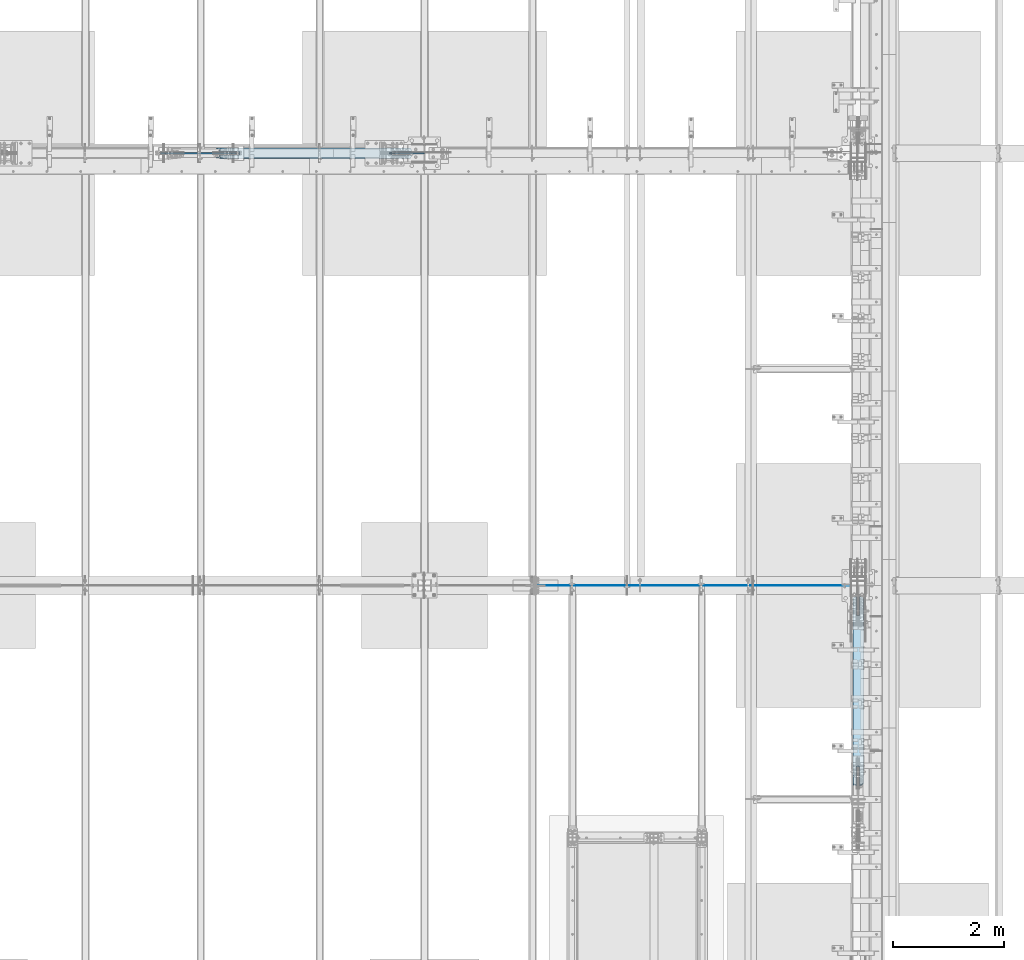
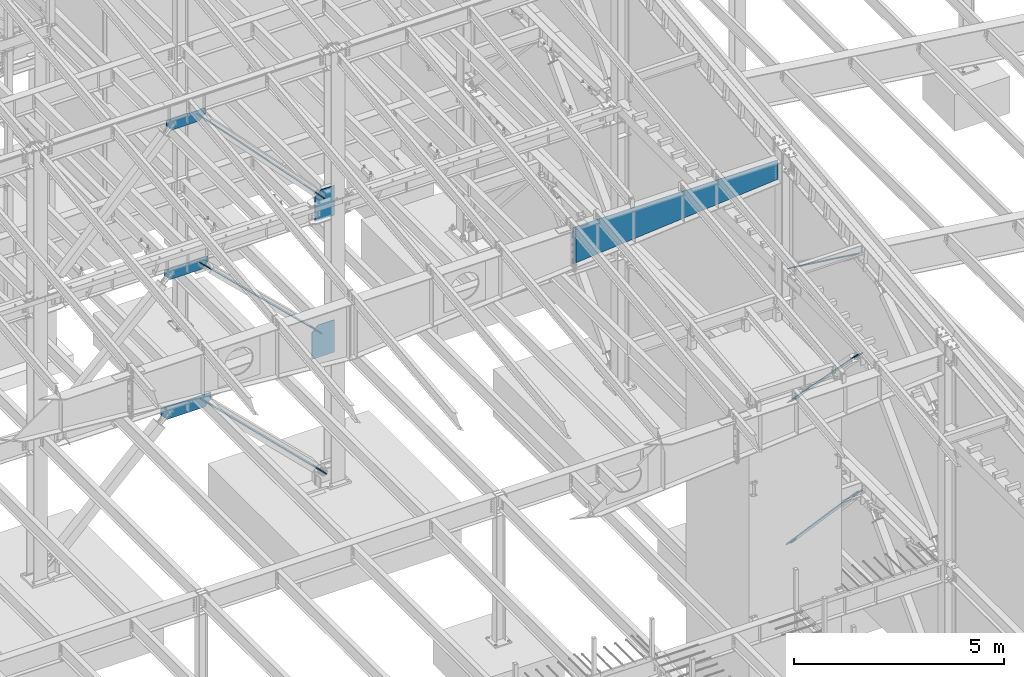
# One storey, part 975 of 1179: 12 plates, 11 elements without a shape of their own.
"""IFC2X3 building model written with IfcOpenShell, lengths in millimetres."""

from ifc_helpers import new_model, si_unit, frame, origin_with_axes, place, context, subcontext, project, spatial, faceted_brep, material, type_object, element, aggregate, save


model = new_model("IFC2X3")

# Units and contexts
model_context = context("Model", 3, precision=1e-05, world=origin_with_axes())
body_context = subcontext(model_context, "Body", "Model", "MODEL_VIEW")
ifc_project = project(units=[si_unit("LENGTHUNIT", "METRE", prefix="MILLI"), si_unit("AREAUNIT", "SQUARE_METRE"), si_unit("VOLUMEUNIT", "CUBIC_METRE"), si_unit("MASSUNIT", "GRAM", prefix="KILO"), si_unit("TIMEUNIT", "SECOND"), si_unit("PLANEANGLEUNIT", "RADIAN"), si_unit("SOLIDANGLEUNIT", "STERADIAN"), si_unit("THERMODYNAMICTEMPERATUREUNIT", "DEGREE_CELSIUS"), si_unit("LUMINOUSINTENSITYUNIT", "LUMEN")], contexts=[model_context])

# Site, building, storey
site_placement = place(None, origin_with_axes())
site = spatial("IfcSite", under=ifc_project, at=site_placement, CompositionType="ELEMENT")
building_placement = place(site_placement, origin_with_axes())
building = spatial("IfcBuilding", under=site, at=building_placement, Name="Undefined", CompositionType="ELEMENT")
storey_placement = place(building_placement, origin_with_axes())
storey = spatial("IfcBuildingStorey", under=building, at=storey_placement, Name="Undefined", CompositionType="ELEMENT", Elevation=0.0)

# Assembly, plate
assembly_1_placement = place(storey_placement, origin_with_axes())
assembly_1 = element("IfcElementAssembly", 1, at=assembly_1_placement, inside=storey, Name="CB", AssemblyPlace="NOTDEFINED", PredefinedType="RIGID_FRAME")
ifc_material_1 = material(Name="STEEL/A36")
plate_type_1 = type_object("IfcPlateType", PredefinedType="NOTDEFINED")
plate_1_placement = place(assembly_1_placement, frame((16156.2657532452, 27141.4875, 8057.37277317872), z_axis=(-0.689394506161204, 0.0, 0.724386095169385), x_axis=(0.0, -1.0, 0.0)))
plate_1 = element("IfcPlate", 2, at=plate_1_placement, type_object=plate_type_1, material=ifc_material_1, Name="CB", context=body_context, shape_type="Brep", body=[
    faceted_brep([(0.0, -6.34999999991851, 71.4374999999018), (0.0, -6.3500000028107, 4998.7655718502), (0.0, 6.34999999719003, 4998.7655718502), (0.0, 6.35000000007858, 71.4374999999018), (5.43785589622348, -6.35000000282525, 5026.1035195498), (5.43785589622348, 6.34999999717184, 5026.10351954979), (20.9235593189878, -6.35000000283981, 5049.27951253124), (20.9235593189878, 6.34999999716092, 5049.27951253124), (44.0995523004203, -6.35000000284708, 5064.76521595401), (44.0995523004203, 6.34999999715001, 5064.76521595401), (71.4375, -6.35000000285072, 5070.20307185024), (71.4375, 6.34999999715001, 5070.20307185024), (71.4375, -6.35000000261425, 4650.48058295178), (71.4375, 6.34999999738284, 4650.48058295178), (109.537499999999, -6.35000000261425, 4650.48058295178), (109.537499999999, 6.34999999738284, 4650.48058295178), (109.537499999999, -6.35000000285072, 5070.20307185024), (109.537499999999, 6.34999999715001, 5070.20307185024), (136.875447699578, -6.35000000284708, 5064.76521595401), (136.875447699578, 6.34999999715001, 5064.76521595401), (160.051440681011, -6.35000000283981, 5049.27951253124), (160.051440681011, 6.34999999716092, 5049.27951253124), (175.537144103775, -6.35000000282525, 5026.1035195498), (175.537144103775, 6.34999999717184, 5026.10351954979), (180.974999999999, -6.3500000028107, 4998.7655718502), (180.974999999999, 6.34999999719003, 4998.7655718502), (180.975000000006, -6.34999999991851, 71.4374999999018), (180.975000000006, 6.35000000007858, 71.4374999999018), (175.537144103779, -6.34999999995125, 44.0995523003585), (175.537144103779, 6.35000000004584, 44.0995523003585), (160.051440681018, -6.34999999997672, 20.9235593189551), (160.051440681018, 6.35000000002401, 20.9235593189587), (136.875447699589, -6.34999999999491, 5.43785589621984), (136.875447699589, 6.35000000000218, 5.43785589621621), (109.537500000006, -6.34999999999854, 3.63797880709171e-12), (109.537500000006, 6.35000000000218, 0.0), (109.537500000006, -6.34999999953288, 419.722488898133), (109.537500000006, 6.35000000046784, 419.722488898133), (71.4375, -6.34999999953288, 419.722488898133), (71.4375, 6.35000000046784, 419.722488898133), (71.4375, -6.34999999999854, 3.63797880709171e-12), (71.4375, 6.35000000000218, 0.0), (44.0995523004167, -6.34999999999491, 5.43785589621984), (44.0995523004167, 6.35000000000218, 5.43785589621621), (20.9235593189878, -6.34999999997672, 20.9235593189551), (20.9235593189878, 6.35000000002401, 20.9235593189587), (5.43785589622712, -6.34999999995125, 44.0995523003585), (5.43785589622712, 6.35000000004584, 44.0995523003585)], [[[0, 1, 2, 3]], [[1, 4, 5, 2]], [[4, 6, 7, 5]], [[6, 8, 9, 7]], [[8, 10, 11, 9]], [[10, 12, 13, 11]], [[12, 14, 15, 13]], [[14, 16, 17, 15]], [[16, 18, 19, 17]], [[18, 20, 21, 19]], [[20, 22, 23, 21]], [[22, 24, 25, 23]], [[24, 26, 27, 25]], [[26, 28, 29, 27]], [[28, 30, 31, 29]], [[30, 32, 33, 31]], [[32, 34, 35, 33]], [[34, 36, 37, 35]], [[36, 38, 39, 37]], [[38, 40, 41, 39]], [[40, 42, 43, 41]], [[42, 44, 45, 43]], [[44, 46, 47, 45]], [[46, 0, 3, 47]], [[5, 7, 9, 11, 13, 15, 17, 19, 21, 23, 25, 27, 29, 31, 33, 35, 37, 39, 41, 43, 45, 47, 3, 2]], [[46, 44, 42, 40, 38, 36, 34, 32, 30, 28, 26, 24, 22, 20, 18, 16, 14, 12, 10, 8, 6, 4, 1, 0]]]),
])
aggregate(assembly_1, [plate_1])

assembly_2_placement = place(storey_placement, origin_with_axes())
assembly_2 = element("IfcElementAssembly", 3, at=assembly_2_placement, inside=storey, Name="CB", AssemblyPlace="NOTDEFINED", PredefinedType="RIGID_FRAME")
plate_2_placement = place(assembly_2_placement, frame((24217.3125, 18933.9955492494, 8077.03369074013), z_axis=(0.0, -0.806042322895358, 0.591857899923162), x_axis=(1.0, 0.0, 0.0)))
plate_2 = element("IfcPlate", 4, at=plate_2_placement, type_object=plate_type_1, material=ifc_material_1, Name="CB", context=body_context, shape_type="Brep", body=[
    faceted_brep([(0.0, -6.34999999991851, 71.4374999999018), (0.0, -6.35000000333093, 3879.50747780775), (0.0, 6.34999999666252, 3879.50747780777), (0.0, 6.35000000007858, 71.4374999999018), (5.43785589622496, -6.3500000033564, 3906.84542550735), (5.43785589622496, 6.34999999664069, 3906.84542550736), (20.923559318986, -6.35000000337459, 3930.0214184888), (20.923559318986, 6.34999999661886, 3930.02141848881), (44.0995523004189, -6.3500000033855, 3945.50712191157), (44.0995523004189, 6.34999999660431, 3945.50712191158), (71.4375, -6.35000000339278, 3950.9449778078), (71.4375, 6.34999999660431, 3950.94497780781), (71.4375, -6.35000000303262, 3531.22248890774), (71.4375, 6.34999999696083, 3531.22248890776), (109.537499999999, -6.35000000303262, 3531.22248890774), (109.537499999999, 6.34999999696083, 3531.22248890776), (109.537499999999, -6.35000000339278, 3950.9449778078), (109.537499999999, 6.34999999660431, 3950.94497780781), (136.87544769958, -6.3500000033855, 3945.50712191157), (136.87544769958, 6.34999999660431, 3945.50712191158), (160.051440681012, -6.35000000337459, 3930.0214184888), (160.051440681012, 6.34999999661886, 3930.02141848881), (175.537144103774, -6.3500000033564, 3906.84542550735), (175.537144103774, 6.34999999664069, 3906.84542550736), (180.974999999999, -6.35000000333093, 3879.50747780775), (180.974999999999, 6.34999999666252, 3879.50747780777), (180.975000000006, -6.34999999991851, 71.4374999999018), (180.975000000006, 6.35000000007858, 71.4374999999018), (175.537144103779, -6.34999999995125, 44.0995523003585), (175.537144103779, 6.35000000004584, 44.0995523003585), (160.051440681018, -6.34999999997672, 20.9235593189551), (160.051440681018, 6.35000000002401, 20.9235593189587), (136.875447699589, -6.34999999999491, 5.43785589621984), (136.875447699589, 6.35000000000218, 5.43785589621621), (109.537500000006, -6.34999999999854, 3.63797880709171e-12), (109.537500000006, 6.35000000000218, 0.0), (109.537500000006, -6.34999999953288, 419.722488898133), (109.537500000006, 6.35000000046784, 419.722488898133), (71.4375, -6.34999999953288, 419.722488898133), (71.4375, 6.35000000046784, 419.722488898133), (71.4375, -6.34999999999854, 3.63797880709171e-12), (71.4375, 6.35000000000218, 0.0), (44.0995523004167, -6.34999999999491, 5.43785589621984), (44.0995523004167, 6.35000000000218, 5.43785589621621), (20.9235593189878, -6.34999999997672, 20.9235593189551), (20.9235593189878, 6.35000000002401, 20.9235593189587), (5.43785589622712, -6.34999999995125, 44.0995523003585), (5.43785589622712, 6.35000000004584, 44.0995523003585)], [[[0, 1, 2, 3]], [[1, 4, 5, 2]], [[4, 6, 7, 5]], [[6, 8, 9, 7]], [[8, 10, 11, 9]], [[10, 12, 13, 11]], [[12, 14, 15, 13]], [[14, 16, 17, 15]], [[16, 18, 19, 17]], [[18, 20, 21, 19]], [[20, 22, 23, 21]], [[22, 24, 25, 23]], [[24, 26, 27, 25]], [[26, 28, 29, 27]], [[28, 30, 31, 29]], [[30, 32, 33, 31]], [[32, 34, 35, 33]], [[34, 36, 37, 35]], [[36, 38, 39, 37]], [[38, 40, 41, 39]], [[40, 42, 43, 41]], [[42, 44, 45, 43]], [[44, 46, 47, 45]], [[46, 0, 3, 47]], [[5, 7, 9, 11, 13, 15, 17, 19, 21, 23, 25, 27, 29, 31, 33, 35, 37, 39, 41, 43, 45, 47, 3, 2]], [[46, 44, 42, 40, 38, 36, 34, 32, 30, 28, 26, 24, 22, 20, 18, 16, 14, 12, 10, 8, 6, 4, 1, 0]]]),
])
aggregate(assembly_2, [plate_2])

assembly_3_placement = place(storey_placement, origin_with_axes())
assembly_3 = element("IfcElementAssembly", 5, at=assembly_3_placement, inside=storey, Name="CB", AssemblyPlace="NOTDEFINED", PredefinedType="RIGID_FRAME")
plate_type_2 = type_object("IfcPlateType", PredefinedType="NOTDEFINED")
plate_3_placement = place(assembly_3_placement, frame((16087.607596845, 27144.6625, 4150.42562094517), z_axis=(-0.719495300867138, 0.0, 0.694497308871752), x_axis=(0.0, -1.0, 0.0)))
plate_3 = element("IfcPlate", 6, at=plate_3_placement, type_object=plate_type_2, material=ifc_material_1, Name="CB", context=body_context, shape_type="Brep", body=[
    faceted_brep([(0.0, -9.52500000000691, 71.4375), (0.0, -9.52500000003238, 4613.90331080685), (0.0, 9.52499999997781, 4613.90331080686), (0.0, 9.52500000000327, 71.4374999999909), (5.43785589622348, -9.52500000003238, 4641.24125850645), (5.43785589622348, 9.52499999997781, 4641.24125850645), (20.9235593189878, -9.52500000003238, 4664.41725148789), (20.9235593189878, 9.52499999997781, 4664.41725148789), (44.0995523004203, -9.52500000003238, 4679.90295491066), (44.0995523004203, 9.52499999997781, 4679.90295491066), (71.4375, -9.52500000003056, 4685.34081080689), (71.4375, 9.52499999997781, 4685.34081080689), (71.4375, -9.52500000002874, 4263.75907000934), (71.4375, 9.52499999998145, 4263.75907000934), (115.887499999997, -9.52500000002874, 4263.75907000934), (115.887499999997, 9.52499999998145, 4263.75907000934), (115.887499999997, -9.52500000003056, 4685.34081080689), (115.887499999997, 9.52499999997781, 4685.34081080689), (143.225447699577, -9.52500000003238, 4679.90295491066), (143.225447699577, 9.52499999997781, 4679.90295491066), (166.401440681009, -9.52500000003238, 4664.41725148789), (166.401440681009, 9.52499999997781, 4664.41725148789), (181.887144103774, -9.52500000003238, 4641.24125850645), (181.887144103774, 9.52499999997781, 4641.24125850645), (187.324999999997, -9.52500000003238, 4613.90331080685), (187.324999999997, 9.52499999997781, 4613.90331080686), (187.324999999997, -9.52500000000691, 71.4375), (187.324999999997, 9.52500000000327, 71.4374999999909), (181.88714410377, -9.52500000000691, 44.0995523004203), (181.88714410377, 9.52500000000509, 44.0995523004112), (166.401440681009, -9.52500000000691, 20.9235593189915), (166.401440681009, 9.52500000000509, 20.9235593189787), (143.22544769958, -9.52500000000327, 5.43785589623076), (143.22544769958, 9.52500000000509, 5.43785589621621), (115.887499999997, -9.52500000000509, 5.45696821063757e-12), (115.887499999997, 9.52500000000691, -7.27595761418343e-12), (115.887499999997, -9.52500000001783, 421.581740798863), (115.887499999997, 9.52499999999418, 421.581740798851), (71.4375, -9.52500000001783, 421.581740798863), (71.4375, 9.52499999999418, 421.581740798851), (71.4375, -9.52500000000509, 5.45696821063757e-12), (71.4375, 9.52500000000691, -7.27595761418343e-12), (44.0995523004167, -9.52500000000327, 5.43785589623076), (44.0995523004167, 9.52500000000509, 5.43785589621621), (20.9235593189878, -9.52500000000691, 20.9235593189915), (20.9235593189878, 9.52500000000509, 20.9235593189787), (5.43785589622712, -9.52500000000691, 44.0995523004203), (5.43785589622712, 9.52500000000509, 44.0995523004112)], [[[0, 1, 2, 3]], [[1, 4, 5, 2]], [[4, 6, 7, 5]], [[6, 8, 9, 7]], [[8, 10, 11, 9]], [[10, 12, 13, 11]], [[12, 14, 15, 13]], [[14, 16, 17, 15]], [[16, 18, 19, 17]], [[18, 20, 21, 19]], [[20, 22, 23, 21]], [[22, 24, 25, 23]], [[24, 26, 27, 25]], [[26, 28, 29, 27]], [[28, 30, 31, 29]], [[30, 32, 33, 31]], [[32, 34, 35, 33]], [[34, 36, 37, 35]], [[36, 38, 39, 37]], [[38, 40, 41, 39]], [[40, 42, 43, 41]], [[42, 44, 45, 43]], [[44, 46, 47, 45]], [[46, 0, 3, 47]], [[5, 7, 9, 11, 13, 15, 17, 19, 21, 23, 25, 27, 29, 31, 33, 35, 37, 39, 41, 43, 45, 47, 3, 2]], [[46, 44, 42, 40, 38, 36, 34, 32, 30, 28, 26, 24, 22, 20, 18, 16, 14, 12, 10, 8, 6, 4, 1, 0]]]),
])
aggregate(assembly_3, [plate_3])

assembly_4_placement = place(storey_placement, origin_with_axes())
assembly_4 = element("IfcElementAssembly", 7, at=assembly_4_placement, inside=storey, Name="CB", AssemblyPlace="NOTDEFINED", PredefinedType="RIGID_FRAME")
plate_4_placement = place(assembly_4_placement, frame((24214.1375, 18978.4459530966, 4148.03570454913), z_axis=(0.0, -0.69846692303685, 0.715642339037759), x_axis=(1.0, 0.0, 0.0)))
plate_4 = element("IfcPlate", 8, at=plate_4_placement, type_object=plate_type_2, material=ifc_material_1, Name="CB", context=body_context, shape_type="Brep", body=[
    faceted_brep([(0.0, -9.52500000000691, 71.4375), (0.0, -9.52499999965221, 4791.84892355422), (0.0, 9.52500000033979, 4791.84892355423), (0.0, 9.52500000000327, 71.4374999999909), (5.43785589622496, -9.52499999964857, 4819.1868712538), (5.43785589622496, 9.52500000034343, 4819.18687125381), (20.923559318986, -9.52499999964857, 4842.36286423524), (20.923559318986, 9.52500000034343, 4842.36286423525), (44.0995523004189, -9.52499999964493, 4857.848567658), (44.0995523004189, 9.52500000034343, 4857.84856765801), (71.4375, -9.52499999964493, 4863.28642355423), (71.4375, 9.52500000034706, 4863.28642355424), (71.4375, -9.52499999967404, 4441.70468275449), (71.4375, 9.52500000031432, 4441.7046827545), (115.8875, -9.52499999967404, 4441.70468275449), (115.8875, 9.52500000031432, 4441.7046827545), (115.8875, -9.52499999964493, 4863.28642355423), (115.8875, 9.52500000034706, 4863.28642355424), (143.225447699581, -9.52499999964493, 4857.848567658), (143.225447699581, 9.52500000034343, 4857.84856765801), (166.401440681014, -9.52499999964857, 4842.36286423524), (166.401440681014, 9.52500000034343, 4842.36286423525), (181.887144103775, -9.52499999964857, 4819.1868712538), (181.887144103775, 9.52500000034343, 4819.18687125381), (187.325, -9.52499999965221, 4791.84892355422), (187.325, 9.52500000033979, 4791.84892355423), (187.324999999997, -9.52500000000691, 71.4375), (187.324999999997, 9.52500000000327, 71.4374999999909), (181.88714410377, -9.52500000000691, 44.0995523004203), (181.88714410377, 9.52500000000509, 44.0995523004112), (166.401440681009, -9.52500000000691, 20.9235593189915), (166.401440681009, 9.52500000000509, 20.9235593189787), (143.22544769958, -9.52500000000327, 5.43785589623076), (143.22544769958, 9.52500000000509, 5.43785589621621), (115.887499999997, -9.52500000000509, 5.45696821063757e-12), (115.887499999997, 9.52500000000691, -7.27595761418343e-12), (115.887499999997, -9.52500000001783, 421.581740798863), (115.887499999997, 9.52499999999418, 421.581740798851), (71.4375, -9.52500000001783, 421.581740798863), (71.4375, 9.52499999999418, 421.581740798851), (71.4375, -9.52500000000509, 5.45696821063757e-12), (71.4375, 9.52500000000691, -7.27595761418343e-12), (44.0995523004167, -9.52500000000327, 5.43785589623076), (44.0995523004167, 9.52500000000509, 5.43785589621621), (20.9235593189878, -9.52500000000691, 20.9235593189915), (20.9235593189878, 9.52500000000509, 20.9235593189787), (5.43785589622712, -9.52500000000691, 44.0995523004203), (5.43785589622712, 9.52500000000509, 44.0995523004112)], [[[0, 1, 2, 3]], [[1, 4, 5, 2]], [[4, 6, 7, 5]], [[6, 8, 9, 7]], [[8, 10, 11, 9]], [[10, 12, 13, 11]], [[12, 14, 15, 13]], [[14, 16, 17, 15]], [[16, 18, 19, 17]], [[18, 20, 21, 19]], [[20, 22, 23, 21]], [[22, 24, 25, 23]], [[24, 26, 27, 25]], [[26, 28, 29, 27]], [[28, 30, 31, 29]], [[30, 32, 33, 31]], [[32, 34, 35, 33]], [[34, 36, 37, 35]], [[36, 38, 39, 37]], [[38, 40, 41, 39]], [[40, 42, 43, 41]], [[42, 44, 45, 43]], [[44, 46, 47, 45]], [[46, 0, 3, 47]], [[5, 7, 9, 11, 13, 15, 17, 19, 21, 23, 25, 27, 29, 31, 33, 35, 37, 39, 41, 43, 45, 47, 3, 2]], [[46, 44, 42, 40, 38, 36, 34, 32, 30, 28, 26, 24, 22, 20, 18, 16, 14, 12, 10, 8, 6, 4, 1, 0]]]),
])
aggregate(assembly_4, [plate_4])

assembly_5_placement = place(storey_placement, origin_with_axes())
assembly_5 = element("IfcElementAssembly", 9, at=assembly_5_placement, inside=storey, Name="CB", AssemblyPlace="NOTDEFINED", PredefinedType="RIGID_FRAME")
plate_type_3 = type_object("IfcPlateType", PredefinedType="NOTDEFINED")
plate_5_placement = place(assembly_5_placement, frame((16219.9942171892, 27147.8375, 18.4770949867459), z_axis=(-0.714279370137245, 0.0, 0.699860687134476), x_axis=(0.0, -1.0, 0.0)))
plate_5 = element("IfcPlate", 10, at=plate_5_placement, type_object=plate_type_3, material=ifc_material_1, Name="CB", context=body_context, shape_type="Brep", body=[
    faceted_brep([(0.0, -12.6999999999871, 65.0875015258525), (0.0, -12.6999999987202, 4798.7012416261), (0.0, 12.7000000012849, 4798.70124162609), (0.0, 12.7000000000194, 65.0875015258407), (4.95449104382351, -12.6999999987129, 4823.60915011408), (4.95449104382351, 12.7000000012922, 4823.60915011408), (19.0636878264413, -12.6999999987092, 4844.72505532553), (19.0636878264413, 12.7000000012977, 4844.72505532552), (40.1795930378867, -12.6999999987038, 4858.83425210814), (40.1795930378867, 12.7000000012995, 4858.83425210813), (65.0875000000015, -12.699999998702, 4863.78874315196), (65.0875000000015, 12.7000000013031, 4863.78874315195), (65.0875000000015, -12.6999999988366, 4364.12194395591), (65.0875000000015, 12.7000000011685, 4364.1219439559), (128.587500000001, -12.6999999988366, 4364.12194395591), (128.587500000001, 12.7000000011685, 4364.1219439559), (128.587498474124, -12.699999998702, 4863.78874315196), (128.587498474124, 12.7000000013031, 4863.78874315195), (153.495406962116, -12.6999999987038, 4858.83425210814), (153.495406962116, 12.7000000012995, 4858.83425210813), (174.611312173562, -12.6999999987092, 4844.72505532553), (174.611312173562, 12.7000000012977, 4844.72505532552), (188.720508956179, -12.6999999987129, 4823.60915011408), (188.720508956179, 12.7000000012922, 4823.60915011408), (193.675000000003, -12.6999999987202, 4798.7012416261), (193.675000000003, 12.7000000012849, 4798.70124162609), (193.675000000003, -12.6999999999871, 65.0875015258525), (193.675000000003, 12.7000000000194, 65.0875015258407), (188.720508956183, -12.6999999999939, 40.1795930378748), (188.720508956183, 12.7000000000126, 40.179593037863), (174.611312173562, -12.6999999999985, 19.0636878264377), (174.611312173562, 12.7000000000075, 19.0636878264249), (153.495406962116, -12.7000000000016, 4.95449104382624), (153.495406962116, 12.7000000000044, 4.95449104381441), (128.587500000001, -12.7000000000035, 8.18545231595635e-12), (128.587500000001, 12.700000000003, -6.3664629124105e-12), (128.587500000001, -12.6999999998793, 499.666799194779), (128.587500000001, 12.7000000001267, 499.666799194767), (65.0875000000015, -12.6999999998793, 499.666799194779), (65.0875000000015, 12.7000000001267, 499.666799194767), (65.0875015258789, -12.7000000000035, 8.18545231595635e-12), (65.0875015258789, 12.700000000003, -6.3664629124105e-12), (40.1795930378867, -12.7000000000016, 4.95449104382624), (40.1795930378867, 12.7000000000044, 4.95449104381441), (19.0636878264413, -12.6999999999985, 19.0636878264377), (19.0636878264413, 12.7000000000075, 19.0636878264249), (4.95449104381987, -12.6999999999939, 40.1795930378748), (4.95449104381987, 12.7000000000126, 40.179593037863)], [[[0, 1, 2, 3]], [[1, 4, 5, 2]], [[4, 6, 7, 5]], [[6, 8, 9, 7]], [[8, 10, 11, 9]], [[10, 12, 13, 11]], [[12, 14, 15, 13]], [[14, 16, 17, 15]], [[16, 18, 19, 17]], [[18, 20, 21, 19]], [[20, 22, 23, 21]], [[22, 24, 25, 23]], [[24, 26, 27, 25]], [[26, 28, 29, 27]], [[28, 30, 31, 29]], [[30, 32, 33, 31]], [[32, 34, 35, 33]], [[34, 36, 37, 35]], [[36, 38, 39, 37]], [[38, 40, 41, 39]], [[40, 42, 43, 41]], [[42, 44, 45, 43]], [[44, 46, 47, 45]], [[46, 0, 3, 47]], [[5, 7, 9, 11, 13, 15, 17, 19, 21, 23, 25, 27, 29, 31, 33, 35, 37, 39, 41, 43, 45, 47, 3, 2]], [[46, 44, 42, 40, 38, 36, 34, 32, 30, 28, 26, 24, 22, 20, 18, 16, 14, 12, 10, 8, 6, 4, 1, 0]]]),
])
aggregate(assembly_5, [plate_5])

# Assembly, plates
assembly_6_placement = place(storey_placement, origin_with_axes())
assembly_6 = element("IfcElementAssembly", 11, at=assembly_6_placement, inside=storey, Name="COLUMN", AssemblyPlace="NOTDEFINED", PredefinedType="RIGID_FRAME")
ifc_material_2 = material(Name="STEEL/A572-GR.50")
plate_type_4 = type_object("IfcPlateType", PredefinedType="NOTDEFINED")
plate_6_placement = place(assembly_6_placement, frame((16452.8499999999, 27051.0, 7445.375), z_axis=(0.0, 0.0, 1.0), x_axis=(-1.0, 0.0, 0.0)))
plate_6 = element("IfcPlate", 12, at=plate_6_placement, type_object=plate_type_4, material=ifc_material_2, Name="PLATE", context=body_context, shape_type="Brep", body=[
    faceted_brep([(0.0, -9.52499999999964, 0.0), (-1.41881173476577e-10, -9.52500000000146, 862.535414371277), (-1.41881173476577e-10, 9.52500000000146, 862.535414371277), (0.0, 9.52499999999964, 0.0), (375.039332806891, -9.52500000000146, 862.535414371277), (375.039332806891, 9.52500000000146, 862.535414371277), (542.933920014775, -9.52500000000146, 702.751002705763), (542.933920014775, 9.52500000000146, 702.751002705763), (542.933920014915, -9.52500000000146, 0.0), (542.933920014915, 9.52500000000146, 0.0)], [[[0, 1, 2, 3]], [[1, 4, 5, 2]], [[4, 6, 7, 5]], [[6, 8, 9, 7]], [[8, 0, 3, 9]], [[5, 7, 9, 3, 2]], [[8, 6, 4, 1, 0]]]),
])
plate_type_5 = type_object("IfcPlateType", PredefinedType="NOTDEFINED")
plate_7_placement = place(assembly_6_placement, frame((16452.85, 27051.0, 3460.75), z_axis=(0.0, 0.0, 1.0), x_axis=(-1.0, 0.0, 0.0)))
plate_7 = element("IfcPlate", 13, at=plate_7_placement, type_object=plate_type_5, material=ifc_material_2, Name="PLATE", context=body_context, shape_type="Brep", body=[
    faceted_brep([(0.0, -9.52499999999964, 0.0), (0.0, -9.52500000000146, 940.236235231712), (0.0, 9.52500000000146, 940.236235231712), (0.0, 9.52499999999964, 0.0), (453.384839102724, -9.52500000000146, 940.236235231712), (453.384839102724, 9.52500000000146, 940.236235231712), (618.762010777811, -9.52500000000146, 768.906416712725), (618.762010777811, 9.52500000000146, 768.906416712725), (618.762010777811, -9.52500000000146, 0.0), (618.762010777811, 9.52500000000146, 0.0)], [[[0, 1, 2, 3]], [[1, 4, 5, 2]], [[4, 6, 7, 5]], [[6, 8, 9, 7]], [[8, 0, 3, 9]], [[5, 7, 9, 3, 2]], [[8, 6, 4, 1, 0]]]),
])
aggregate(assembly_6, [plate_6, plate_7])

# Assembly, plate
assembly_7_placement = place(storey_placement, origin_with_axes())
assembly_7 = element("IfcElementAssembly", 14, at=assembly_7_placement, inside=storey, Name="BEAM", AssemblyPlace="NOTDEFINED", PredefinedType="RIGID_FRAME")
plate_type_6 = type_object("IfcPlateType", PredefinedType="NOTDEFINED")
plate_8_placement = place(assembly_7_placement, frame((11682.7933815895, 27051.0, 3288.94554728214), z_axis=(1.0, 0.0, 0.0), x_axis=(0.0, 0.0, 1.0)))
plate_8 = element("IfcPlate", 15, at=plate_8_placement, type_object=plate_type_6, material=ifc_material_2, Name="PLATE", context=body_context, shape_type="Brep", body=[
    faceted_brep([(0.0, -12.7, 0.0), (-174.623449014303, -12.7000000000007, 171.0984414872), (-174.623449014303, 12.7000000000007, 171.0984414872), (0.0, 12.7, 0.0), (-174.623449014303, -12.7000000000007, 693.356618597156), (-174.623449014303, 12.7000000000007, 693.356618597156), (-174.623449014303, -12.7000000000007, 1202.91479533381), (-174.623449014303, 12.7000000000007, 1202.91479533381), (1.86613760888577e-07, -12.7000000000007, 1374.01323700385), (1.86613760888577e-07, 12.7000000000007, 1374.01323700385), (190.85445271786, -12.7000000000007, 1374.01323700385), (190.85445271786, 12.7000000000007, 1374.01323700385), (190.85445271786, -12.7000000000007, 0.0), (190.85445271786, 12.7000000000007, 0.0)], [[[0, 1, 2, 3]], [[1, 4, 5, 2]], [[4, 6, 7, 5]], [[6, 8, 9, 7]], [[8, 10, 11, 9]], [[10, 12, 13, 11]], [[12, 0, 3, 13]], [[5, 7, 9, 11, 13, 3, 2]], [[12, 10, 8, 6, 4, 1, 0]]]),
])
aggregate(assembly_7, [plate_8])

assembly_8_placement = place(storey_placement, origin_with_axes())
assembly_8 = element("IfcElementAssembly", 16, at=assembly_8_placement, inside=storey, Name="BEAM", AssemblyPlace="NOTDEFINED", PredefinedType="RIGID_FRAME")
plate_type_7 = type_object("IfcPlateType", PredefinedType="NOTDEFINED")
plate_9_placement = place(assembly_8_placement, frame((11769.5534918783, 27051.0, 7325.15094989935), z_axis=(1.0, 0.0, 0.0), x_axis=(0.0, 0.0, 1.0)))
plate_9 = element("IfcPlate", 17, at=plate_9_placement, type_object=plate_type_7, material=ifc_material_2, Name="PLATE", context=body_context, shape_type="Brep", body=[
    faceted_brep([(0.0, -9.52499999999964, 0.0), (-174.871873520778, -9.52500000000146, 168.796162108289), (-174.871873520778, 9.52500000000146, 168.796162108289), (0.0, 9.52499999999964, 0.0), (-174.871873730764, -9.52500000000146, 606.596509721659), (-174.871873730764, 9.52500000000146, 606.596509721659), (-174.871873934634, -9.52500000000146, 1031.69641039643), (-174.871873934634, 9.52500000000146, 1031.69641039643), (0.000458959779280121, -9.52500000000146, 1200.49301624073), (0.000458959779280121, 9.52500000000146, 1200.49301624073), (139.274049524961, -9.52500000000146, 1200.4930163071), (139.274049524961, 9.52500000000146, 1200.4930163071), (139.274050100698, -9.52500000000146, 0.0), (139.274050100698, 9.52500000000146, 0.0)], [[[0, 1, 2, 3]], [[1, 4, 5, 2]], [[4, 6, 7, 5]], [[6, 8, 9, 7]], [[8, 10, 11, 9]], [[10, 12, 13, 11]], [[12, 0, 3, 13]], [[5, 7, 9, 11, 13, 3, 2]], [[12, 10, 8, 6, 4, 1, 0]]]),
])
aggregate(assembly_8, [plate_9])

assembly_9_placement = place(storey_placement, origin_with_axes())
assembly_9 = element("IfcElementAssembly", 18, at=assembly_9_placement, inside=storey, Name="BEAM", AssemblyPlace="NOTDEFINED", PredefinedType="RIGID_FRAME")
plate_type_8 = type_object("IfcPlateType", PredefinedType="NOTDEFINED")
plate_10_placement = place(assembly_9_placement, frame((11832.3547145402, 27051.0, 11639.4041503228), z_axis=(1.0, 0.0, 0.0), x_axis=(0.0, 0.0, 1.0)))
plate_10 = element("IfcPlate", 19, at=plate_10_placement, type_object=plate_type_8, material=ifc_material_2, Name="PLATE", context=body_context, shape_type="Brep", body=[
    faceted_brep([(0.0, -9.52499999999964, 0.0), (-159.78441340453, -9.52500000000146, 167.89458903517), (-159.78441340453, 9.52500000000146, 167.89458903517), (0.0, 9.52499999999964, 0.0), (-159.78441340453, -9.52500000000146, 543.795283632486), (-159.78441340453, 9.52500000000146, 543.795283632486), (-159.78441340453, -9.52500000000146, 906.995981884371), (-159.78441340453, 9.52500000000146, 906.995981884371), (-1.73901753441896e-06, -9.52500000000146, 1074.89056909225), (-1.73901753441896e-06, 9.52500000000146, 1074.89056909225), (163.26147471287, -9.52500000000146, 1074.89056909225), (163.26147471287, 9.52500000000146, 1074.89056909225), (163.26147471287, -9.52500000000146, 0.0), (163.26147471287, 9.52500000000146, 0.0)], [[[0, 1, 2, 3]], [[1, 4, 5, 2]], [[4, 6, 7, 5]], [[6, 8, 9, 7]], [[8, 10, 11, 9]], [[10, 12, 13, 11]], [[12, 0, 3, 13]], [[5, 7, 9, 11, 13, 3, 2]], [[12, 10, 8, 6, 4, 1, 0]]]),
])
aggregate(assembly_9, [plate_10])

assembly_10_placement = place(storey_placement, origin_with_axes())
assembly_10 = element("IfcElementAssembly", 20, at=assembly_10_placement, inside=storey, Name="CB", AssemblyPlace="NOTDEFINED", PredefinedType="RIGID_FRAME")
plate_type_9 = type_object("IfcPlateType", PredefinedType="NOTDEFINED")
plate_11_placement = place(assembly_10_placement, frame((24212.55, 19018.1469828896, 6.46967490713081), z_axis=(0.0, -0.68599585875867, 0.727605443744036), x_axis=(1.0, 0.0, 0.0)))
plate_11 = element("IfcPlate", 21, at=plate_11_placement, type_object=plate_type_9, material=ifc_material_1, Name="CB", context=body_context, shape_type="Brep", body=[
    faceted_brep([(0.0, -12.700000000139, 66.6750030518815), (0.0, -12.7000000021235, 4899.51727466588), (0.0, 12.6999999978489, 4899.5172746659), (0.0, 12.6999999998006, 66.6750030519361), (5.0753324021112, -12.7000000021344, 4925.03269368669), (5.0753324021112, 12.6999999978379, 4925.03269368671), (19.5286562582261, -12.7000000021453, 4946.66362145943), (19.5286562582261, 12.699999997827, 4946.66362145945), (41.1595840309583, -12.7000000021508, 4961.11694531555), (41.1595840309583, 12.6999999978198, 4961.11694531558), (66.675, -12.7000000021526, 4966.19227771766), (66.675, 12.6999999978179, 4966.19227771769), (66.675, -12.7000000019343, 4467.47113886627), (66.675, 12.6999999980362, 4467.4711388663), (123.825, -12.7000000019343, 4467.47113886627), (123.825, 12.6999999980362, 4467.4711388663), (123.824996948242, -12.7000000021526, 4966.19227771766), (123.824996948242, 12.6999999978179, 4966.19227771769), (149.340415969042, -12.7000000021508, 4961.11694531555), (149.340415969042, 12.6999999978198, 4961.11694531558), (170.971343741774, -12.7000000021453, 4946.66362145943), (170.971343741774, 12.699999997827, 4946.66362145945), (185.424667597889, -12.7000000021344, 4925.03269368669), (185.424667597889, 12.6999999978379, 4925.03269368671), (190.5, -12.7000000021235, 4899.51727466588), (190.5, 12.6999999978489, 4899.5172746659), (190.5, -12.700000000139, 66.6750030518815), (190.5, 12.6999999998006, 66.6750030519361), (185.424667597889, -12.7000000000735, 41.159584031022), (185.424667597889, 12.6999999998661, 41.1595840310729), (170.971343741774, -12.7000000000189, 19.5286562582405), (170.971343741774, 12.6999999999171, 19.5286562582951), (149.340415969042, -12.6999999999825, 5.07533240209159), (149.340415969042, 12.6999999999571, 5.07533240214616), (123.824999618709, -12.7000000000002, 0.0), (123.8249996187, 12.6999999999996, 0.0), (123.825, -12.7000000002045, 498.721138851377), (123.825, 12.6999999997697, 498.721138851402), (66.675, -12.7000000002045, 498.721138851377), (66.675, 12.6999999997697, 498.721138851402), (66.6750030517578, -12.699999999968, -2.91038304567337e-11), (66.6750030517578, 12.699999999968, 2.91038304567337e-11), (41.1595840309583, -12.6999999999825, 5.07533240209159), (41.1595840309583, 12.6999999999571, 5.07533240214616), (19.5286562582261, -12.7000000000189, 19.5286562582405), (19.5286562582261, 12.6999999999171, 19.5286562582951), (5.0753324021112, -12.7000000000735, 41.159584031022), (5.0753324021112, 12.6999999998661, 41.1595840310729)], [[[0, 1, 2, 3]], [[1, 4, 5, 2]], [[4, 6, 7, 5]], [[6, 8, 9, 7]], [[8, 10, 11, 9]], [[10, 12, 13, 11]], [[12, 14, 15, 13]], [[14, 16, 17, 15]], [[16, 18, 19, 17]], [[18, 20, 21, 19]], [[20, 22, 23, 21]], [[22, 24, 25, 23]], [[24, 26, 27, 25]], [[26, 28, 29, 27]], [[28, 30, 31, 29]], [[30, 32, 33, 31]], [[32, 34, 35, 33]], [[34, 36, 37, 35]], [[36, 38, 39, 37]], [[38, 40, 41, 39]], [[40, 42, 43, 41]], [[42, 44, 45, 43]], [[44, 46, 47, 45]], [[46, 0, 3, 47]], [[5, 7, 9, 11, 13, 15, 17, 19, 21, 23, 25, 27, 29, 31, 33, 35, 37, 39, 41, 43, 45, 47, 3, 2]], [[46, 44, 42, 40, 38, 36, 34, 32, 30, 28, 26, 24, 22, 20, 18, 16, 14, 12, 10, 8, 6, 4, 1, 0]]]),
])
aggregate(assembly_10, [plate_11])

assembly_11_placement = place(storey_placement, origin_with_axes())
assembly_11 = element("IfcElementAssembly", 22, at=assembly_11_placement, inside=storey, Name="RAFTER BEAM", AssemblyPlace="NOTDEFINED", PredefinedType="RIGID_FRAME")
plate_type_10 = type_object("IfcPlateType", PredefinedType="NOTDEFINED")
plate_12_placement = place(assembly_11_placement, frame((24137.938, 19227.7999999987, 11105.35625), z_axis=(0.0, 0.0, -1.0), x_axis=(-1.0, 0.0, 0.0)))
plate_12 = element("IfcPlate", 23, at=plate_12_placement, type_object=plate_type_10, material=ifc_material_1, Name="RAFTER BEAM", context=body_context, shape_type="Brep", body=[
    faceted_brep([(5557.83799999999, -7.9375, 1052.02301271788), (5557.83799999999, -7.9375, -2.7648638933897e-10), (5557.83799999999, 7.9375, -2.7648638933897e-10), (5557.83799999999, 7.9375, 1052.02301271788), (5573.71299999999, -7.9375, 1053.41391033749), (5573.71299999999, -7.9375, -2.7648638933897e-10), (0.0, -7.9375, 0.0), (0.000499699228384998, -7.9375, 565.069756066781), (0.000499699228384998, 7.9375, 565.069756066781), (0.0, 7.9375, 0.0), (5646.73800009591, 7.9375, -2.80124368146062e-10), (5646.73800009591, -7.9375, -2.80124368146062e-10), (5646.73800009591, -7.9375, 1059.81203939609), (5646.73800009591, 7.9375, 1059.81203939609)], [[[0, 1, 2, 3]], [[4, 3, 2, 5]], [[6, 7, 8, 9]], [[6, 9, 2, 1]], [[7, 6, 1, 0]], [[8, 7, 0, 3]], [[10, 11, 5, 2]], [[11, 12, 4, 5]], [[10, 13, 12, 11]], [[2, 9, 8, 3, 13, 10]], [[12, 13, 3, 4]]]),
])
aggregate(assembly_11, [plate_12])

save(model, "model.ifc")
